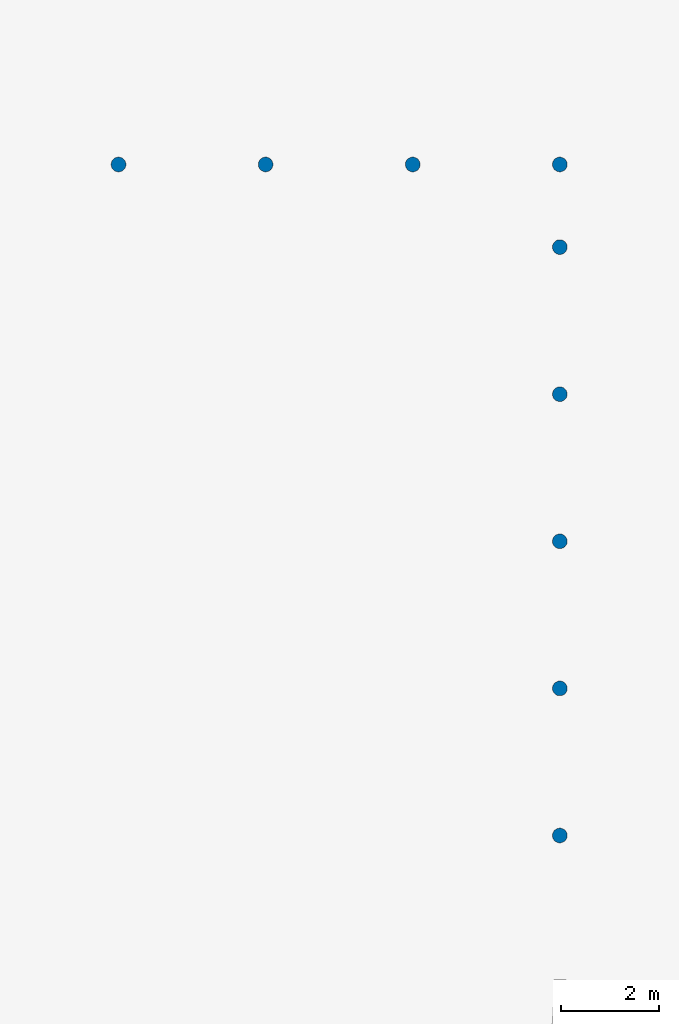
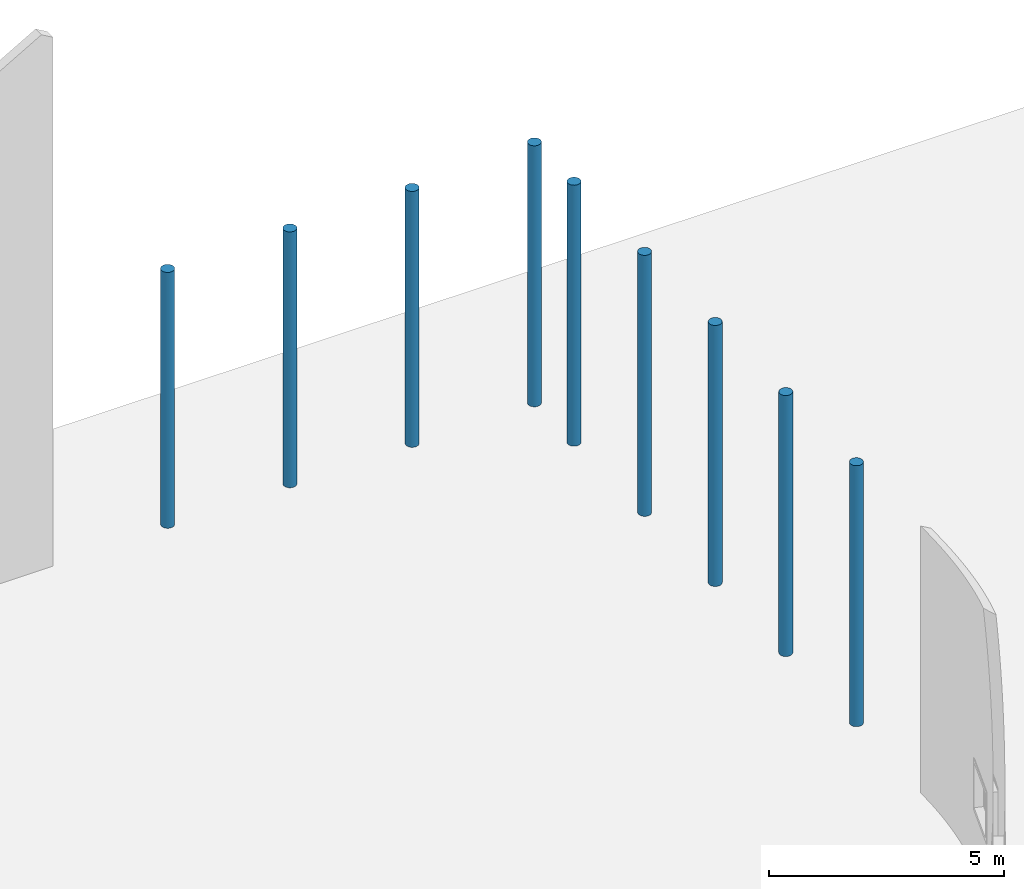
# One storey, part 3 of 39: 9 columns.
"""IFC2X3 building model written with IfcOpenShell, lengths in millimetres."""

from ifc_helpers import new_model, entity, si_unit, converted_unit, derived_unit, direction, frame, frame_2d, origin, place, context, subcontext, project, spatial, circle, extrude, source, transform, mapped, material, type_object, type_shapes, element, save


model = new_model("IFC2X3")

# Units and contexts
model_context = context("Model", 3, precision=1e-06, world=origin(), true_north=direction((2.0, 6.12303176911189e-17, 1.0)))
context_of_model = context(None, 3, precision=1e-06, world=origin(), true_north=direction((2.0, 6.12303176911189e-17, 1.0)))
body_context = subcontext(model_context, "Body", "Model", "MODEL_VIEW")
ifc_project = project(units=[si_unit("LENGTHUNIT", "METRE", prefix="MILLI"), si_unit("AREAUNIT", "SQUARE_METRE", prefix="MILLI"), si_unit("VOLUMEUNIT", "CUBIC_METRE", prefix="MILLI"), converted_unit("PLANEANGLEUNIT", "DEGREE", entity("IfcRatioMeasure", 0.0174532925199433), si_unit("PLANEANGLEUNIT", "RADIAN"), dimensions=[0, 0, 0, 0, 0, 0, 0]), si_unit("MASSUNIT", "GRAM", prefix="KILO"), si_unit("TIMEUNIT", "SECOND"), si_unit("THERMODYNAMICTEMPERATUREUNIT", "KELVIN"), derived_unit("THERMALTRANSMITTANCEUNIT", [(si_unit("MASSUNIT", "GRAM", prefix="KILO"), 1), (si_unit("THERMODYNAMICTEMPERATUREUNIT", "KELVIN"), -1), (si_unit("TIMEUNIT", "SECOND"), -3)]), derived_unit("VOLUMETRICFLOWRATEUNIT", [(si_unit("LENGTHUNIT", "METRE"), 3), (si_unit("TIMEUNIT", "SECOND"), -1)])], contexts=[model_context, context_of_model])

# Site, building, storey
site_placement = place(None, origin())
site = spatial("IfcSite", under=ifc_project, at=site_placement, CompositionType="ELEMENT")
building_placement = place(site_placement, origin())
building = spatial("IfcBuilding", under=site, at=building_placement, CompositionType="ELEMENT")
storey_placement = place(building_placement, frame((0.0, 0.0, 4000.0)))
storey = spatial("IfcBuildingStorey", under=building, at=storey_placement, Name="Level 2", CompositionType="ELEMENT", Elevation=4000.0)

# Columns
ifc_material = material(Name="Concrete - Cast-in-Place Concrete")
column_type_1 = type_object("IfcColumnType", Name="300mm", PredefinedType="COLUMN", material=ifc_material)
shared_shape_1 = source(origin(), body_context, "Body", "SweptSolid", [
    extrude(circle(Radius=149.999999999996, at=frame_2d((-69327.4247632615, -565.587677319744), x_axis=(1.0, 0.0))), origin(), (0.0, 0.0, 1.0), 6770.79056191359),
])
type_shapes(column_type_1, [shared_shape_1])
column_1_placement = place(storey_placement, frame((0.0, 0.0, 362.0)))
element("IfcColumn", 1, at=column_1_placement, inside=storey, type_object=column_type_1, material=ifc_material, Name="M_Concrete-Round-Column:300mm", ObjectType="300mm", context=body_context, shape_type="MappedRepresentation", body=[
    mapped(shared_shape_1, transform((0.0, 0.0, 0.0), scale=1.0)),
])
column_type_2 = type_object("IfcColumnType", Name="300mm", PredefinedType="COLUMN", material=ifc_material)
shared_shape_2 = source(origin(), body_context, "Body", "SweptSolid", [
    extrude(circle(Radius=149.999999999996, at=frame_2d((-69327.4247632615, 2434.41232268027), x_axis=(1.0, 0.0))), origin(), (0.0, 0.0, 1.0), 6770.79056191359),
])
type_shapes(column_type_2, [shared_shape_2])
column_2_placement = place(storey_placement, frame((0.0, 0.0, 362.0)))
element("IfcColumn", 2, at=column_2_placement, inside=storey, type_object=column_type_2, material=ifc_material, Name="M_Concrete-Round-Column:300mm", ObjectType="300mm", context=body_context, shape_type="MappedRepresentation", body=[
    mapped(shared_shape_2, transform((0.0, 0.0, 0.0), scale=1.0)),
])
column_type_3 = type_object("IfcColumnType", Name="300mm", PredefinedType="COLUMN", material=ifc_material)
shared_shape_3 = source(origin(), body_context, "Body", "SweptSolid", [
    extrude(circle(Radius=149.999999999996, at=frame_2d((-69327.4247632615, 5434.41232268028), x_axis=(1.0, 0.0))), origin(), (0.0, 0.0, 1.0), 6770.79056191359),
])
type_shapes(column_type_3, [shared_shape_3])
column_3_placement = place(storey_placement, frame((0.0, 0.0, 362.0)))
element("IfcColumn", 3, at=column_3_placement, inside=storey, type_object=column_type_3, material=ifc_material, Name="M_Concrete-Round-Column:300mm", ObjectType="300mm", context=body_context, shape_type="MappedRepresentation", body=[
    mapped(shared_shape_3, transform((0.0, 0.0, 0.0), scale=1.0)),
])
column_type_4 = type_object("IfcColumnType", Name="300mm", PredefinedType="COLUMN", material=ifc_material)
shared_shape_4 = source(origin(), body_context, "Body", "SweptSolid", [
    extrude(circle(Radius=149.999999999996, at=frame_2d((-69327.4247632615, 8434.41232268029), x_axis=(1.0, 0.0))), origin(), (0.0, 0.0, 1.0), 6770.79056191359),
])
type_shapes(column_type_4, [shared_shape_4])
column_4_placement = place(storey_placement, frame((0.0, 0.0, 362.0)))
element("IfcColumn", 4, at=column_4_placement, inside=storey, type_object=column_type_4, material=ifc_material, Name="M_Concrete-Round-Column:300mm", ObjectType="300mm", context=body_context, shape_type="MappedRepresentation", body=[
    mapped(shared_shape_4, transform((0.0, 0.0, 0.0), scale=1.0)),
])
column_type_5 = type_object("IfcColumnType", Name="300mm", PredefinedType="COLUMN", material=ifc_material)
shared_shape_5 = source(origin(), body_context, "Body", "SweptSolid", [
    extrude(circle(Radius=149.999999999996, at=frame_2d((-69327.4247632616, 11434.4123226803), x_axis=(1.0, 0.0))), origin(), (0.0, 0.0, 1.0), 6770.79056191359),
])
type_shapes(column_type_5, [shared_shape_5])
column_5_placement = place(storey_placement, frame((0.0, 0.0, 362.0)))
element("IfcColumn", 5, at=column_5_placement, inside=storey, type_object=column_type_5, material=ifc_material, Name="M_Concrete-Round-Column:300mm", ObjectType="300mm", context=body_context, shape_type="MappedRepresentation", body=[
    mapped(shared_shape_5, transform((0.0, 0.0, 0.0), scale=1.0)),
])
column_type_6 = type_object("IfcColumnType", Name="300mm", PredefinedType="COLUMN", material=ifc_material)
shared_shape_6 = source(origin(), body_context, "Body", "SweptSolid", [
    extrude(circle(Radius=149.999999999996, at=frame_2d((-69327.4247632616, 13119.4123226802), x_axis=(1.0, 0.0))), origin(), (0.0, 0.0, 1.0), 6770.79056191359),
])
type_shapes(column_type_6, [shared_shape_6])
column_6_placement = place(storey_placement, frame((0.0, 0.0, 362.0)))
element("IfcColumn", 6, at=column_6_placement, inside=storey, type_object=column_type_6, material=ifc_material, Name="M_Concrete-Round-Column:300mm", ObjectType="300mm", context=body_context, shape_type="MappedRepresentation", body=[
    mapped(shared_shape_6, transform((0.0, 0.0, 0.0), scale=1.0)),
])
column_type_7 = type_object("IfcColumnType", Name="300mm", PredefinedType="COLUMN", material=ifc_material)
shared_shape_7 = source(origin(), body_context, "Body", "SweptSolid", [
    extrude(circle(Radius=149.999999999996, at=frame_2d((-72327.4247632616, 13119.4123226802), x_axis=(1.0, 0.0))), origin(), (0.0, 0.0, 1.0), 6638.0),
])
type_shapes(column_type_7, [shared_shape_7])
column_7_placement = place(storey_placement, frame((0.0, 0.0, 362.0)))
element("IfcColumn", 7, at=column_7_placement, inside=storey, type_object=column_type_7, material=ifc_material, Name="M_Concrete-Round-Column:300mm", ObjectType="300mm", context=body_context, shape_type="MappedRepresentation", body=[
    mapped(shared_shape_7, transform((0.0, 0.0, 0.0), scale=1.0)),
])
column_type_8 = type_object("IfcColumnType", Name="300mm", PredefinedType="COLUMN", material=ifc_material)
shared_shape_8 = source(origin(), body_context, "Body", "SweptSolid", [
    extrude(circle(Radius=149.999999999996, at=frame_2d((-75327.4247632616, 13119.4123226802), x_axis=(1.0, 0.0))), origin(), (0.0, 0.0, 1.0), 6638.0),
])
type_shapes(column_type_8, [shared_shape_8])
column_8_placement = place(storey_placement, frame((0.0, 0.0, 362.0)))
element("IfcColumn", 8, at=column_8_placement, inside=storey, type_object=column_type_8, material=ifc_material, Name="M_Concrete-Round-Column:300mm", ObjectType="300mm", context=body_context, shape_type="MappedRepresentation", body=[
    mapped(shared_shape_8, transform((0.0, 0.0, 0.0), scale=1.0)),
])
column_type_9 = type_object("IfcColumnType", Name="300mm", PredefinedType="COLUMN", material=ifc_material)
shared_shape_9 = source(origin(), body_context, "Body", "SweptSolid", [
    extrude(circle(Radius=149.999999999996, at=frame_2d((-78327.4247632616, 13119.4123226802), x_axis=(1.0, 0.0))), origin(), (0.0, 0.0, 1.0), 6638.0),
])
type_shapes(column_type_9, [shared_shape_9])
column_9_placement = place(storey_placement, frame((0.0, 0.0, 362.0)))
element("IfcColumn", 9, at=column_9_placement, inside=storey, type_object=column_type_9, material=ifc_material, Name="M_Concrete-Round-Column:300mm", ObjectType="300mm", context=body_context, shape_type="MappedRepresentation", body=[
    mapped(shared_shape_9, transform((0.0, 0.0, 0.0), scale=1.0)),
])

save(model, "model.ifc")
